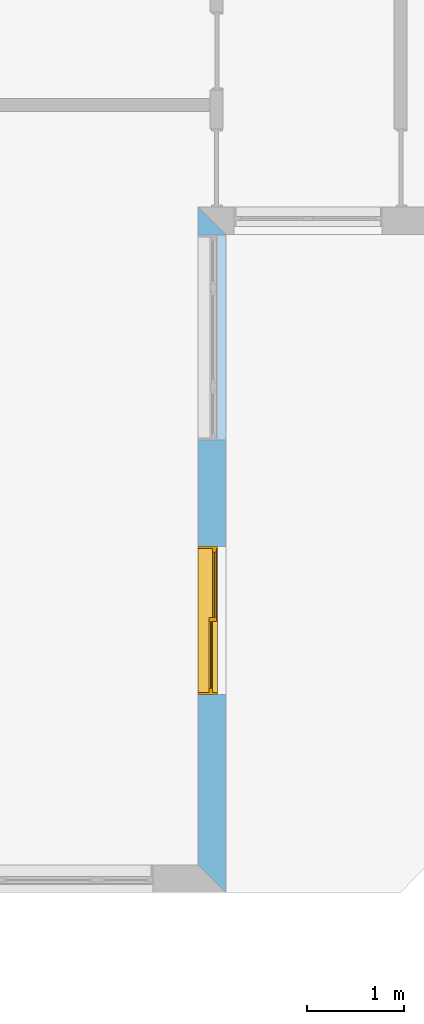
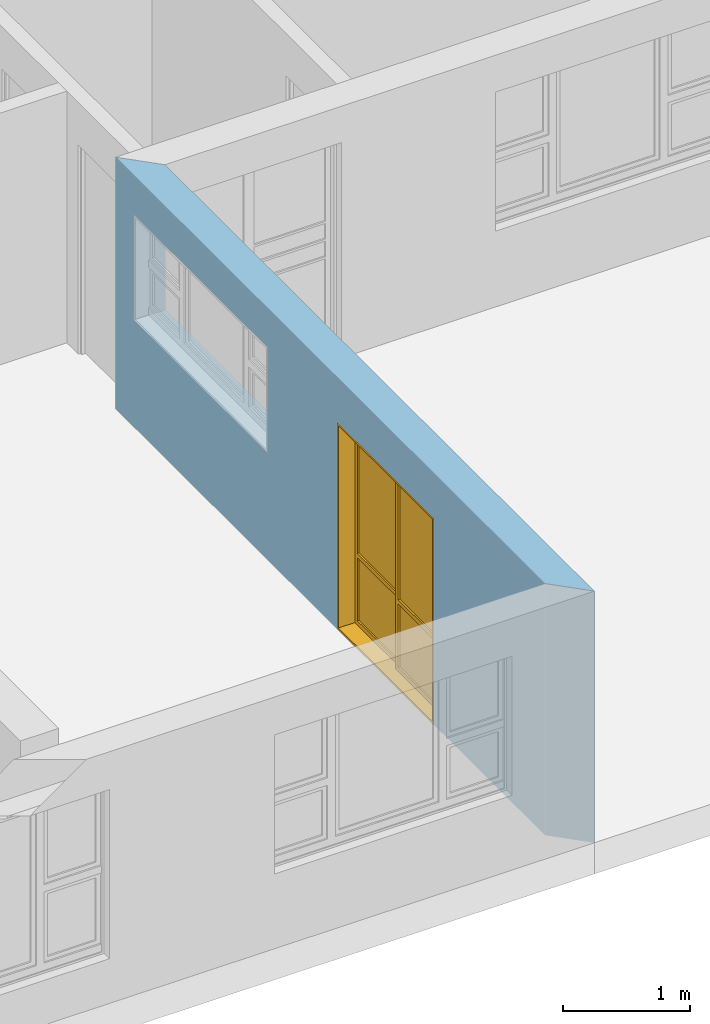
# One storey, part 11 of 15: 1 window, 2 openings, plus 1 element that does not belong to this part.
"""IFC4 building model written with IfcOpenShell, lengths in millimetres."""

from ifc_helpers import new_model, entity, si_unit, converted_unit, frame, origin_with_axes, origin_2d_with_axis, place, context, subcontext, project, spatial, line, indexed_curve, outline, extrude, clip, halfspace, polygons, source, transform, mapped, material, layer, layer_set, layer_usage, type_object, type_shapes, element, fill, save


model = new_model("IFC4")

# Units and contexts
model_context = context("Model", 3, precision=1e-05, world=origin_with_axes())
plan_context = context("Plan", 2, precision=1e-05, world=origin_2d_with_axis())
body_context = subcontext(model_context, "Body", "Model", "MODEL_VIEW")
ifc_project = project(units=[si_unit("VOLUMEUNIT", "CUBIC_METRE"), si_unit("LENGTHUNIT", "METRE", prefix="MILLI"), converted_unit("PLANEANGLEUNIT", "degree", entity("IfcReal", 0.0174532925199433), si_unit("PLANEANGLEUNIT", "RADIAN"), dimensions=[0, 0, 0, 0, 0, 0, 0]), si_unit("AREAUNIT", "SQUARE_METRE")], contexts=[model_context, plan_context])

# Site, building, storey
site_placement = place(None, origin_with_axes())
site = spatial("IfcSite", under=ifc_project, at=site_placement)
building_placement = place(site_placement, origin_with_axes())
building = spatial("IfcBuilding", under=site, at=building_placement, Name="Building")
storey_placement = place(building_placement, origin_with_axes())
storey = spatial("IfcBuildingStorey", under=building, at=storey_placement, Name="EXISTING")

# Wall, openings, window
ifc_material = material()
ifc_layer = layer(ifc_material, 285.0, Name="brick")
ifc_layer_set = layer_set([ifc_layer])
ifc_layer_usage = layer_usage(ifc_layer_set, "AXIS2", "POSITIVE", 0.0)
wall_type = type_object("IfcWallType", Name="285mm Wall", PredefinedType="STANDARD", material=ifc_layer_set)
wall_placement = place(storey_placement, frame((13494.119644165, -4518.33248138428, 0.0), z_axis=(0.0, 0.0, 1.0), x_axis=(3.13916473260163e-07, 0.999999999999951, 0.0)))
wall = element("IfcWall", 1, at=wall_placement, inside=storey, type_object=wall_type, material=ifc_layer_usage, Name="Wall", context=body_context, shape_type="Clipping", body=[
    clip(clip(extrude(outline(indexed_curve([(0.0, 0.0), (0.0, 285.0), (7060.00143769791, 285.0), (7060.00143769791, 0.0), (0.0, 0.0)], self_intersect=False)), origin_with_axes(), (0.0, 0.0, 1.0), 2425.00019073486), halfspace(frame((2.32475940720178e-05, 5.74426053390198e-05, 0.0), z_axis=(-0.707106709480286, 0.707106828689575, 0.0), x_axis=(0.707106840791191, 0.707106721581899, 0.0)), False)), halfspace(frame((6775.00104904175, 0.000276878381555434, 0.0), z_axis=(0.70710700750351, -0.707106530666351, 0.0), x_axis=(-0.707106542767924, -0.70710701960509, 0.0)), False)),
])
shared_shape_1 = source(origin_with_axes(), body_context, "Body", "SweptSolid", [
    extrude(outline(indexed_curve([(0.0, 0.0), (2110.00024414062, 0.0), (2110.00024414062, 1014.99993896484), (0.0, 1014.99993896484)], segments=[line(1, 2, 3, 4, 1)])), frame((1.19209282445354e-07, -600.0, 0.0), z_axis=(0.0, -1.0, 0.0), x_axis=(1.0, 0.0, 0.0)), (0.0, 0.0, -1.0), 1200.0),
])
opening_1_placement = place(wall_placement, frame((6771.17128867833, 136.111477694053, 1030.00009059906), z_axis=(0.0, 0.0, 1.0), x_axis=(-0.999999999999999, -3.17864987664478e-08, 0.0)))
element("IfcOpeningElement", 2, at=opening_1_placement, cuts=wall, PredefinedType="OPENING", context=body_context, shape_type="MappedRepresentation", body=[
    mapped(shared_shape_1, transform((0.0, 0.0, 0.0), x_axis=(1.0, 0.0, 0.0), y_axis=(0.0, 1.0, 0.0), z_axis=(0.0, 0.0, 1.0), scale=1.0)),
])
shared_shape_2 = source(origin_with_axes(), body_context, "Body", "SweptSolid", [
    extrude(outline(indexed_curve([(0.0, 0.0), (1525.00085449219, 0.0), (1525.00085449219, 1990.0), (0.0, 1990.0)], segments=[line(1, 2, 3, 4, 1)])), frame((-3.57627840230634e-07, -600.0, 0.0), z_axis=(0.0, -1.0, 0.0), x_axis=(1.0, 0.0, 0.0)), (0.0, 0.0, -1.0), 1200.0),
])
opening_2_placement = place(wall_placement, frame((3565.00013056336, 146.110700105945, 0.0), z_axis=(0.0, 0.0, 1.0), x_axis=(-0.999999999999999, -3.17864987664478e-08, 0.0)))
opening_2 = element("IfcOpeningElement", 3, at=opening_2_placement, cuts=wall, PredefinedType="OPENING", context=body_context, shape_type="MappedRepresentation", body=[
    mapped(shared_shape_2, transform((0.0, 0.0, 0.0), x_axis=(1.0, 0.0, 0.0), y_axis=(0.0, 1.0, 0.0), z_axis=(0.0, 0.0, 1.0), scale=1.0)),
])
window_type = type_object("IfcWindowType", Name="Ex.1525x1990", PartitioningType="NOTDEFINED", PredefinedType="WINDOW")
shared_shape_3 = source(origin_with_axes(), body_context, "Body", "Tessellation", [
    polygons([(1525.00061035156, -138.888946533203, 0.0), (1525.00061035156, -138.888946533203, 19.999979019165), (0.000596046389546245, -138.889007568359, 0.0), (0.000596046389546245, -138.889007568359, 19.999979019165), (1525.00061035156, 61.1110305786133, 0.0), (1525.00061035156, 61.1110305786133, 19.999979019165), (0.000596046389546245, 61.110969543457, 0.0), (0.000596046389546245, 61.110969543457, 19.999979019165), (0.000119209282274824, -138.888946533203, 19.999979019165), (20.0005760192871, -138.888946533203, 19.999979019165), (0.000119209282274824, -138.889007568359, 1970.00012207031), (20.0000991821289, -138.889007568359, 1970.00012207031), (0.000119209282274824, 61.1110305786133, 19.999979019165), (20.0000991821289, 61.1110305786133, 19.999979019165), (-0.000357627839548513, 61.110969543457, 1970.00012207031), (20.0000991821289, 61.110969543457, 1970.00012207031), (1505.00061035156, -138.888946533203, 19.999979019165), (1525.00061035156, -138.888946533203, 19.999979019165), (1505.00061035156, -138.889007568359, 1970.00012207031), (1525.00061035156, -138.889007568359, 1970.00012207031), (1505.00061035156, 61.1110305786133, 19.999979019165), (1525.00061035156, 61.1110305786133, 19.999979019165), (1505.00061035156, 61.110969543457, 1970.00012207031), (1525.00061035156, 61.110969543457, 1970.00012207031), (1525.00061035156, -138.888946533203, 1970.00012207031), (1525.00061035156, -138.888946533203, 1990.00012207031), (0.000596046389546245, -138.889007568359, 1970.00012207031), (0.000596046389546245, -138.889007568359, 1990.00012207031), (1525.00061035156, 61.1110305786133, 1970.00012207031), (1525.00061035156, 61.1110305786133, 1990.00012207031), (0.000596046389546245, 61.110969543457, 1970.00012207031), (0.000596046389546245, 61.110969543457, 1990.00012207031), (1505.00061035156, -28.8887004852295, 1969.99914550781), (1465.00256347656, -28.8887004852295, 1969.99914550781), (1505.00061035156, -28.8887004852295, 60.0003547668457), (1465.00207519531, -28.8887004852295, 60.0003547668457), (1505.00061035156, 11.1112585067749, 1969.99914550781), (1465.00256347656, 11.1112585067749, 1969.99914550781), (1505.00061035156, 11.1112585067749, 60.0003547668457), (1465.00207519531, 11.1113185882568, 60.0003547668457), (772.501525878906, -28.8887004852295, 1969.99914550781), (732.502990722656, -28.8887004852295, 1969.99914550781), (772.501037597656, -28.8887004852295, 60.0004768371582), (732.502990722656, -28.8887004852295, 60.0004768371582), (772.501525878906, 11.1112585067749, 1969.99914550781), (732.502990722656, 11.1112585067749, 1969.99914550781), (772.501037597656, 11.1112585067749, 60.0004768371582), (732.502990722656, 11.1113185882568, 60.0004768371582), (1505.00012207031, -28.8887004852295, 20.0004558563232), (1505.00012207031, -28.8887004852295, 60.0002975463867), (732.502563476562, -28.8887596130371, 20.0006942749023), (732.502563476562, -28.8887596130371, 60.0004768371582), (1505.00012207031, 11.1112585067749, 20.0004558563232), (1505.00012207031, 11.1112585067749, 60.0002975463867), (732.502563476562, 11.1111392974854, 20.0006942749023), (732.502563476562, 11.1111392974854, 60.0004768371582), (1465.00305175781, -28.8887004852295, 670.001708984375), (1465.00305175781, -28.8887004852295, 710.000915527344), (772.501037597656, -28.8887596130371, 670.002624511719), (772.501037597656, -28.8887596130371, 710.001708984375), (1465.00305175781, 11.1112585067749, 670.001708984375), (1465.00305175781, 11.1112585067749, 710.000915527344), (772.501037597656, 11.1111392974854, 670.002624511719), (772.501037597656, 11.1111392974854, 710.001708984375), (1465.00256347656, -13.8887157440186, 670.001892089844), (772.500610351562, -13.8887157440186, 670.001831054688), (1465.00256347656, -13.8887157440186, 60.000415802002), (772.500122070312, -13.8887157440186, 60.0004768371582), (1465.00256347656, -3.88872599601746, 670.001892089844), (772.500610351562, -3.88872599601746, 670.001831054688), (1465.00256347656, -3.88872599601746, 60.000415802002), (772.500122070312, -3.88872599601746, 60.0004768371582), (1465.00256347656, -28.8881645202637, 1969.99914550781), (772.500610351562, -28.8884620666504, 1969.99963378906), (1465.00256347656, -28.8881645202637, 1929.99975585938), (772.500610351562, -28.8884620666504, 1930.0), (1465.00256347656, 11.1114377975464, 1969.99914550781), (772.500610351562, 11.1111993789673, 1969.99963378906), (1465.00256347656, 11.1114377975464, 1929.99975585938), (772.500610351562, 11.1111993789673, 1930.0), (1465.00256347656, -13.8887157440186, 1930.00024414062), (772.500610351562, -13.8887157440186, 1930.00024414062), (1465.00256347656, -13.8887157440186, 710.001770019531), (772.500122070312, -13.8887157440186, 710.001770019531), (1465.00256347656, -3.88872599601746, 1930.00024414062), (772.500610351562, -3.88872599601746, 1930.00024414062), (1465.00256347656, -3.88872599601746, 710.001770019531), (772.500122070312, -3.88872599601746, 710.001770019531), (772.499145507812, 11.1110801696777, 1969.99914550781), (732.501098632812, 11.1110801696777, 1969.99914550781), (772.499145507812, 11.1110801696777, 60.0003547668457), (732.500610351562, 11.1110801696777, 60.0003547668457), (772.499145507812, 51.1110992431641, 1969.99914550781), (732.501098632812, 51.1110992431641, 1969.99914550781), (772.499145507812, 51.1110992431641, 60.0003547668457), (732.500610351562, 51.1110992431641, 60.0003547668457), (59.9986267089844, 11.1110801696777, 1969.99914550781), (20.0000991821289, 11.1110801696777, 1969.99914550781), (59.9981498718262, 11.1110801696777, 60.0004768371582), (19.9996223449707, 11.1110801696777, 60.0004768371582), (59.9986267089844, 51.1110992431641, 1969.99914550781), (20.0000991821289, 51.1110992431641, 1969.99914550781), (59.9981498718262, 51.1110992431641, 60.0004768371582), (20.0000991821289, 51.1110992431641, 60.0004768371582), (772.499633789062, 11.1111392974854, 20.0004558563232), (772.499633789062, 11.1111392974854, 60.0002975463867), (19.9996223449707, 11.1110200881958, 20.0006942749023), (19.9996223449707, 11.1110200881958, 60.0004768371582), (772.499633789062, 51.1110382080078, 20.0004558563232), (772.499633789062, 51.1110382080078, 60.0002975463867), (19.9996223449707, 51.1109809875488, 20.0006942749023), (19.9996223449707, 51.1109809875488, 60.0004768371582), (732.501586914062, 11.1111392974854, 670.001708984375), (732.501586914062, 11.1111392974854, 710.000915527344), (59.9986267089844, 11.1110200881958, 670.002624511719), (59.9986267089844, 11.1110200881958, 710.001708984375), (732.501586914062, 51.1110382080078, 670.001708984375), (732.501586914062, 51.1110382080078, 710.000915527344), (59.9986267089844, 51.1109809875488, 670.002624511719), (59.9986267089844, 51.1109809875488, 710.001708984375), (732.501098632812, 26.1110649108887, 670.001892089844), (59.9981498718262, 26.1110649108887, 670.001770019531), (732.501098632812, 26.1110649108887, 60.000415802002), (59.997673034668, 26.1110649108887, 60.0004768371582), (732.501098632812, 36.1110534667969, 670.001892089844), (59.9981498718262, 36.1111145019531, 670.001770019531), (732.501098632812, 36.1111145019531, 60.000415802002), (59.997673034668, 36.1111145019531, 60.0004768371582), (732.501098632812, 11.1116161346436, 1969.99914550781), (59.9981498718262, 11.1113185882568, 1969.99963378906), (732.501098632812, 11.1116161346436, 1929.99975585938), (59.9981498718262, 11.1113777160645, 1930.0), (732.501098632812, 51.1112174987793, 1969.99914550781), (59.9981498718262, 51.1109809875488, 1969.99963378906), (732.501098632812, 51.1112174987793, 1929.99975585938), (59.9981498718262, 51.1109809875488, 1930.0), (732.501098632812, 26.1110649108887, 1930.00024414062), (59.9981498718262, 26.1110649108887, 1930.0), (732.501098632812, 26.1110649108887, 710.001770019531), (59.997673034668, 26.1110649108887, 710.001708984375), (732.501098632812, 36.1110534667969, 1930.00024414062), (59.9981498718262, 36.1111145019531, 1930.0), (732.501098632812, 36.1111145019531, 710.001770019531), (59.997673034668, 36.1111145019531, 710.001708984375)], [[[1, 2, 4, 3]], [[3, 4, 8, 7]], [[7, 8, 6, 5]], [[5, 6, 2, 1]], [[3, 7, 5, 1]], [[8, 4, 2, 6]], [[9, 10, 12, 11]], [[11, 12, 16, 15]], [[15, 16, 14, 13]], [[13, 14, 10, 9]], [[11, 15, 13, 9]], [[16, 12, 10, 14]], [[17, 18, 20, 19]], [[19, 20, 24, 23]], [[23, 24, 22, 21]], [[21, 22, 18, 17]], [[19, 23, 21, 17]], [[24, 20, 18, 22]], [[25, 26, 28, 27]], [[27, 28, 32, 31]], [[31, 32, 30, 29]], [[29, 30, 26, 25]], [[27, 31, 29, 25]], [[32, 28, 26, 30]], [[33, 34, 36, 35]], [[35, 36, 40, 39]], [[39, 40, 38, 37]], [[37, 38, 34, 33]], [[35, 39, 37, 33]], [[40, 36, 34, 38]], [[41, 42, 44, 43]], [[43, 44, 48, 47]], [[47, 48, 46, 45]], [[45, 46, 42, 41]], [[43, 47, 45, 41]], [[48, 44, 42, 46]], [[49, 50, 52, 51]], [[51, 52, 56, 55]], [[55, 56, 54, 53]], [[53, 54, 50, 49]], [[51, 55, 53, 49]], [[56, 52, 50, 54]], [[57, 58, 60, 59]], [[59, 60, 64, 63]], [[63, 64, 62, 61]], [[61, 62, 58, 57]], [[59, 63, 61, 57]], [[64, 60, 58, 62]], [[65, 66, 68, 67]], [[67, 68, 72, 71]], [[71, 72, 70, 69]], [[69, 70, 66, 65]], [[67, 71, 69, 65]], [[72, 68, 66, 70]], [[73, 74, 76, 75]], [[75, 76, 80, 79]], [[79, 80, 78, 77]], [[77, 78, 74, 73]], [[75, 79, 77, 73]], [[80, 76, 74, 78]], [[81, 82, 84, 83]], [[83, 84, 88, 87]], [[87, 88, 86, 85]], [[85, 86, 82, 81]], [[83, 87, 85, 81]], [[88, 84, 82, 86]], [[89, 90, 92, 91]], [[91, 92, 96, 95]], [[95, 96, 94, 93]], [[93, 94, 90, 89]], [[91, 95, 93, 89]], [[96, 92, 90, 94]], [[97, 98, 100, 99]], [[99, 100, 104, 103]], [[103, 104, 102, 101]], [[101, 102, 98, 97]], [[99, 103, 101, 97]], [[104, 100, 98, 102]], [[105, 106, 108, 107]], [[107, 108, 112, 111]], [[111, 112, 110, 109]], [[109, 110, 106, 105]], [[107, 111, 109, 105]], [[112, 108, 106, 110]], [[113, 114, 116, 115]], [[115, 116, 120, 119]], [[119, 120, 118, 117]], [[117, 118, 114, 113]], [[115, 119, 117, 113]], [[120, 116, 114, 118]], [[121, 122, 124, 123]], [[123, 124, 128, 127]], [[127, 128, 126, 125]], [[125, 126, 122, 121]], [[123, 127, 125, 121]], [[128, 124, 122, 126]], [[129, 130, 132, 131]], [[131, 132, 136, 135]], [[135, 136, 134, 133]], [[133, 134, 130, 129]], [[131, 135, 133, 129]], [[136, 132, 130, 134]], [[137, 138, 140, 139]], [[139, 140, 144, 143]], [[143, 144, 142, 141]], [[141, 142, 138, 137]], [[139, 143, 141, 137]], [[144, 140, 138, 142]]], closed=True),
])
type_shapes(window_type, [shared_shape_3])
window_placement = place(opening_2_placement, frame((0.000596046708656317, -0.000953674131665139, 0.0), z_axis=(0.0, 0.0, 1.0), x_axis=(0.999999999999983, -1.82782315505365e-07, 0.0)))
window = element("IfcWindow", 4, at=window_placement, inside=storey, type_object=window_type, Name="Window", context=body_context, shape_type="MappedRepresentation", body=[
    mapped(shared_shape_3, transform((0.0, 0.0, 0.0), x_axis=(1.0, 0.0, 0.0), y_axis=(0.0, 1.0, 0.0), z_axis=(0.0, 0.0, 1.0), scale=1.0)),
])
fill(opening_2, window)

save(model, "model.ifc")
